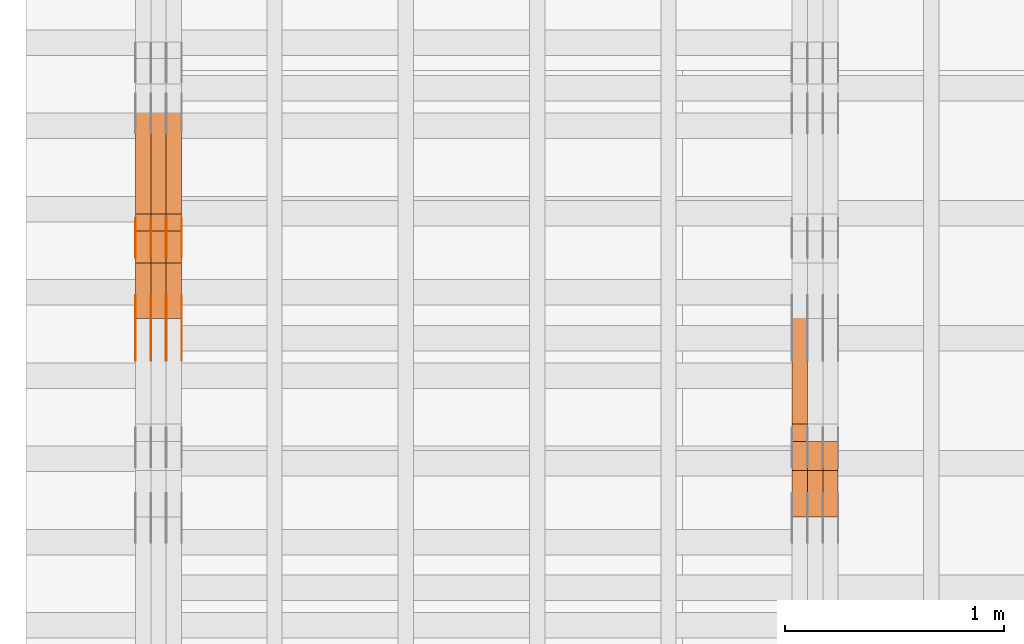
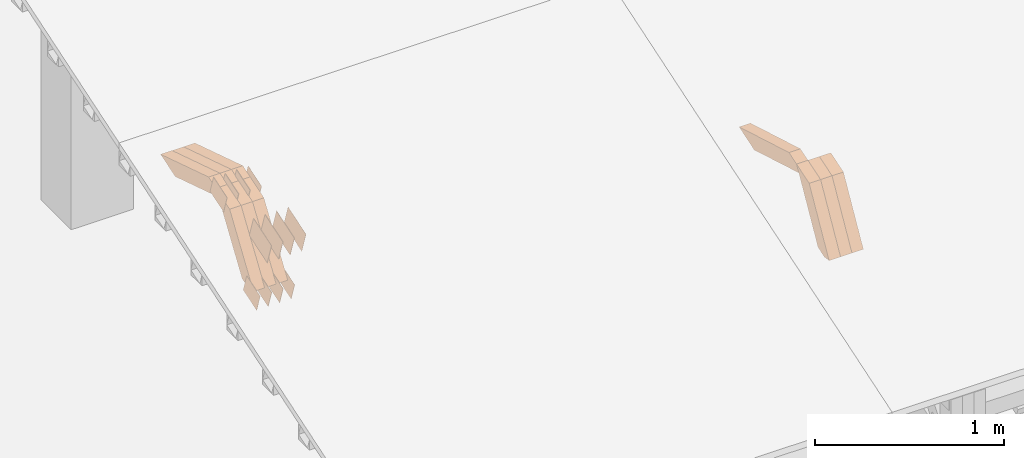
# One storey, part 36 of 385: 28 proxies.
"""IFC2X3 building model written with IfcOpenShell, lengths in millimetres."""

import ifcopenshell
import ifcopenshell.guid

model = None  # the IFC model being written
_history = None  # IfcOwnerHistory: only IFC2X3 demands one
_inside = {}  # id of a spatial element -> (the spatial element, [elements in it])
_under = {}  # id of a project, library or spatial element -> (it, [spatial elements below it])
_declared = {}  # id of a project -> (the project, [libraries it declares])
_typed = {}  # id of a type object -> (the type object, [elements of that type])
_made_of = {}  # id of a material, layer set ... -> (it, [elements and type objects made of it])


def new_model(schema):
    """Start an empty IFC model of exactly this schema.

    Asked for "IFC4X3", IfcOpenShell would pick the latest addendum, in which some entities
    have other attributes; the version numbers below select the first issue.
    IFC2X3 requires an IfcOwnerHistory on every rooted entity: one is made here for all.
    """
    global model, _history
    if schema == "IFC4X3":
        model = ifcopenshell.file(schema_version=(4, 3, 0, 0))
    else:
        model = ifcopenshell.file(schema=schema)
    _inside.clear()
    _under.clear()
    _declared.clear()
    _typed.clear()
    _made_of.clear()
    _history = None
    if model.schema == "IFC2X3":
        org = make("IfcOrganization", Name="unknown")
        user = make(
            "IfcPersonAndOrganization",
            ThePerson=make("IfcPerson", FamilyName="unknown"),
            TheOrganization=org,
        )
        app = make(
            "IfcApplication",
            ApplicationDeveloper=org,
            Version="unknown",
            ApplicationFullName="unknown",
            ApplicationIdentifier="unknown",
        )
        _history = make(
            "IfcOwnerHistory",
            OwningUser=user,
            OwningApplication=app,
            ChangeAction="ADDED",
            CreationDate=0,
        )
    return model


def make(cls, **values):
    """One entity of the class cls with the attributes given. An attribute that is None is left unset."""
    return model.create_entity(
        cls, **{name: value for name, value in values.items() if value is not None}
    )


def entity(cls, *values):
    """Any entity or typed value of the class cls, its attributes in the order of the schema. None: left unset."""
    e = model.create_entity(cls)
    for i, value in enumerate(values):
        if value is not None:
            e[i] = value
    return e


def rooted(cls, **values):
    """An entity with a GlobalId (a new one), such as an element, a storey or a relation."""
    return make(cls, GlobalId=ifcopenshell.guid.new(), OwnerHistory=_history, **values)


def si_unit(unit_type, name, prefix=None):
    """IfcSIUnit, for example si_unit("LENGTHUNIT", "METRE", prefix="MILLI")."""
    return make("IfcSIUnit", UnitType=unit_type, Prefix=prefix, Name=name)


def converted_unit(unit_type, name, factor, base, dimensions=None, offset=None):
    """IfcConversionBasedUnit, such as the inch: factor (a typed value) times the base unit."""
    return make(
        "IfcConversionBasedUnit"
        if offset is None
        else "IfcConversionBasedUnitWithOffset",
        ConversionOffset=offset,
        Dimensions=None
        if dimensions is None
        else entity("IfcDimensionalExponents", *dimensions),
        UnitType=unit_type,
        Name=name,
        ConversionFactor=make(
            "IfcMeasureWithUnit", ValueComponent=factor, UnitComponent=base
        ),
    )


def derived_unit(unit_type, elements):
    """IfcDerivedUnit: a product of units, each with its exponent."""
    return make(
        "IfcDerivedUnit",
        Elements=[
            make("IfcDerivedUnitElement", Unit=unit, Exponent=power)
            for unit, power in elements
        ],
        UnitType=unit_type,
    )


def assignment(units):
    """IfcUnitAssignment: the units of a project."""
    return None if units is None else make("IfcUnitAssignment", Units=units)


def point(xyz):
    """IfcCartesianPoint."""
    return None if xyz is None else make("IfcCartesianPoint", Coordinates=xyz)


def direction(xyz):
    """IfcDirection."""
    return None if xyz is None else make("IfcDirection", DirectionRatios=xyz)


def frame(location, z_axis=None, x_axis=None):
    """IfcAxis2Placement3D, a coordinate frame: its origin and axes. An axis left out is left unset."""
    return make(
        "IfcAxis2Placement3D",
        Location=point(location),
        Axis=direction(z_axis),
        RefDirection=direction(x_axis),
    )


def origin():
    """The frame at (0, 0, 0) with its axes left unset."""
    return frame((0.0, 0.0, 0.0))


def place(relative_to, where):
    """IfcLocalPlacement: puts the frame where relative to a parent placement (None: the world)."""
    return make(
        "IfcLocalPlacement", PlacementRelTo=relative_to, RelativePlacement=where
    )


def context(
    kind, dimensions, precision=None, world=None, true_north=None, identifier=None
):
    """IfcGeometricRepresentationContext, for example the 3D "Model" context."""
    return make(
        "IfcGeometricRepresentationContext",
        ContextIdentifier=identifier,
        ContextType=kind,
        CoordinateSpaceDimension=dimensions,
        Precision=precision,
        WorldCoordinateSystem=world,
        TrueNorth=true_north,
    )


def subcontext(parent, identifier, kind, view, scale=None):
    """IfcGeometricRepresentationSubContext, for example "Body" below "Model"."""
    return make(
        "IfcGeometricRepresentationSubContext",
        ContextIdentifier=identifier,
        ContextType=kind,
        ParentContext=parent,
        TargetScale=scale,
        TargetView=view,
    )


def project(units=None, contexts=None):
    """IfcProject with its units and contexts."""
    return rooted(
        "IfcProject",
        Name="project",
        RepresentationContexts=contexts,
        UnitsInContext=assignment(units),
    )


def spatial(cls, under=None, at=None, **own):
    """A site, building, storey or space (cls), placed at a placement, below another one or the project."""
    s = rooted(cls, ObjectPlacement=at, **own)
    if under is not None:
        _under.setdefault(under.id(), (under, []))[1].append(s)
    return s


def polyline(points):
    """IfcPolyline through the points."""
    return make("IfcPolyline", Points=[point(p) for p in points])


def outline(outer, holes=None, kind="AREA"):
    """IfcArbitraryClosedProfileDef: a profile drawn as a closed curve; with holes, ...WithVoids."""
    if holes is None:
        return make("IfcArbitraryClosedProfileDef", ProfileType=kind, OuterCurve=outer)
    return make(
        "IfcArbitraryProfileDefWithVoids",
        ProfileType=kind,
        OuterCurve=outer,
        InnerCurves=holes,
    )


def extrude(swept, where, along, depth):
    """IfcExtrudedAreaSolid: the profile swept, set in the frame where, extruded along a direction by depth."""
    return make(
        "IfcExtrudedAreaSolid",
        SweptArea=swept,
        Position=where,
        ExtrudedDirection=direction(along),
        Depth=depth,
    )


def shape(context_of_items, identifier, shape_type, items):
    """IfcShapeRepresentation: the items that make up one representation, for example the "Body"."""
    return make(
        "IfcShapeRepresentation",
        ContextOfItems=context_of_items,
        RepresentationIdentifier=identifier,
        RepresentationType=shape_type,
        Items=items,
    )


def source(mapping_origin, context_of_items, identifier, shape_type, items):
    """IfcRepresentationMap: a shape defined once, which mapped items show again and again."""
    return make(
        "IfcRepresentationMap",
        MappingOrigin=mapping_origin,
        MappedRepresentation=shape(context_of_items, identifier, shape_type, items),
    )


def transform(
    local_origin,
    x_axis=None,
    y_axis=None,
    z_axis=None,
    scale=None,
    scale2=None,
    scale3=None,
    uniform=True,
):
    """IfcCartesianTransformationOperator3D, or its non-uniform kind. x_axis, y_axis, z_axis: its Axis1, 2, 3."""
    if uniform:
        return make(
            "IfcCartesianTransformationOperator3D",
            Axis1=direction(x_axis),
            Axis2=direction(y_axis),
            LocalOrigin=point(local_origin),
            Scale=scale,
            Axis3=direction(z_axis),
        )
    return make(
        "IfcCartesianTransformationOperator3DnonUniform",
        Axis1=direction(x_axis),
        Axis2=direction(y_axis),
        LocalOrigin=point(local_origin),
        Scale=scale,
        Axis3=direction(z_axis),
        Scale2=scale2,
        Scale3=scale3,
    )


def mapped(mapping_source, mapping_target):
    """IfcMappedItem: shows the shape of a source again, moved by a transform."""
    return make(
        "IfcMappedItem", MappingSource=mapping_source, MappingTarget=mapping_target
    )


def material(Name=None, Category=None):
    """IfcMaterial."""
    return make("IfcMaterial", Name=Name, Category=Category)


def made_of(thing, what):
    """Note that an element or type object is made of a material, layer set ...; save() writes the relation."""
    if what is not None:
        _made_of.setdefault(what.id(), (what, []))[1].append(thing)
    return thing


def type_object(cls, material=None, **own):
    """A type object (cls), such as IfcWallType, which elements share."""
    return made_of(rooted(cls, **own), material)


def type_shapes(of_type, sources):
    """Give a type object the sources (RepresentationMaps) that its elements show as mapped items."""
    of_type.RepresentationMaps = sources


def element(
    cls,
    number,
    at=None,
    inside=None,
    cuts=None,
    type_object=None,
    material=None,
    context=None,
    identifier="Body",
    shape_type=None,
    held_by="IfcProductDefinitionShape",
    body=None,
    shapes=None,
    **own,
):
    """One element of the class cls, such as IfcWall. Its Tag is "e" and its number.

    at: its placement. inside: the storey or other place that contains it. cuts: it is an
    opening in that element (IfcRelVoidsElement). A single representation is given by context,
    identifier, shape_type and body (its items); several are given by shapes. held_by: the class
    of the entity that holds the representations. save() writes the other relations.
    """
    e = rooted(cls, Tag="e%d" % number, ObjectPlacement=at, **own)
    if body is not None:
        shapes = [shape(context, identifier, shape_type, body)]
    if shapes is not None:
        e.Representation = make(held_by, Representations=shapes)
    if inside is not None:
        _inside.setdefault(inside.id(), (inside, []))[1].append(e)
    if cuts is not None:
        rooted(
            "IfcRelVoidsElement", RelatingBuildingElement=cuts, RelatedOpeningElement=e
        )
    if type_object is not None:
        _typed.setdefault(type_object.id(), (type_object, []))[1].append(e)
    return made_of(e, material)


def aggregate(whole, parts):
    """IfcRelAggregates: a whole, such as a stair, and the parts it consists of."""
    return rooted("IfcRelAggregates", RelatingObject=whole, RelatedObjects=parts)


def save(model, path):
    """Write the relations noted so far, then the file.

    IfcRelAggregates (storeys below a building ...), IfcRelContainedInSpatialStructure (elements
    in a storey), IfcRelDefinesByType, IfcRelAssociatesMaterial and IfcRelDeclares: one each for
    every whole, place, type object, material and project.
    """
    for whole, parts in _under.values():
        aggregate(whole, parts)
    for where, things in _inside.values():
        rooted(
            "IfcRelContainedInSpatialStructure",
            RelatedElements=things,
            RelatingStructure=where,
        )
    for kind, things in _typed.values():
        rooted("IfcRelDefinesByType", RelatedObjects=things, RelatingType=kind)
    for what, things in _made_of.values():
        rooted("IfcRelAssociatesMaterial", RelatedObjects=things, RelatingMaterial=what)
    for by, libraries in _declared.values():
        rooted("IfcRelDeclares", RelatingContext=by, RelatedDefinitions=libraries)
    model.write(path)


model = new_model("IFC2X3")

# Units and contexts
model_context = context("Model", 3, precision=0.01, world=origin(), true_north=direction((6.12303176911189e-17, 1.0)))
body_context = subcontext(model_context, "Body", "Model", "MODEL_VIEW")
ifc_project = project(units=[si_unit("LENGTHUNIT", "METRE", prefix="MILLI"), si_unit("AREAUNIT", "SQUARE_METRE"), si_unit("VOLUMEUNIT", "CUBIC_METRE"), converted_unit("PLANEANGLEUNIT", "DEGREE", entity("IfcRatioMeasure", 0.0174532925199433), si_unit("PLANEANGLEUNIT", "RADIAN"), dimensions=[0, 0, 0, 0, 0, 0, 0]), si_unit("MASSUNIT", "GRAM", prefix="KILO"), derived_unit("MASSDENSITYUNIT", [(si_unit("MASSUNIT", "GRAM", prefix="KILO"), 1), (si_unit("LENGTHUNIT", "METRE"), -3)]), si_unit("TIMEUNIT", "SECOND"), si_unit("FREQUENCYUNIT", "HERTZ"), si_unit("THERMODYNAMICTEMPERATUREUNIT", "DEGREE_CELSIUS"), derived_unit("THERMALTRANSMITTANCEUNIT", [(si_unit("MASSUNIT", "GRAM", prefix="KILO"), 1), (si_unit("THERMODYNAMICTEMPERATUREUNIT", "KELVIN"), -1), (si_unit("TIMEUNIT", "SECOND"), -3)]), derived_unit("VOLUMETRICFLOWRATEUNIT", [(si_unit("LENGTHUNIT", "METRE"), 3), (si_unit("TIMEUNIT", "SECOND"), -1)]), si_unit("ELECTRICCURRENTUNIT", "AMPERE"), si_unit("ELECTRICVOLTAGEUNIT", "VOLT"), si_unit("POWERUNIT", "WATT"), si_unit("FORCEUNIT", "NEWTON", prefix="KILO"), si_unit("ILLUMINANCEUNIT", "LUX"), si_unit("LUMINOUSFLUXUNIT", "LUMEN"), si_unit("LUMINOUSINTENSITYUNIT", "CANDELA"), derived_unit("USERDEFINED", [(si_unit("MASSUNIT", "GRAM", prefix="KILO"), -1), (si_unit("LENGTHUNIT", "METRE"), -2), (si_unit("TIMEUNIT", "SECOND"), 3), (si_unit("LUMINOUSFLUXUNIT", "LUMEN"), 1)]), derived_unit("LINEARVELOCITYUNIT", [(si_unit("LENGTHUNIT", "METRE"), 1), (si_unit("TIMEUNIT", "SECOND"), -1)]), si_unit("PRESSUREUNIT", "PASCAL"), derived_unit("USERDEFINED", [(si_unit("LENGTHUNIT", "METRE"), -2), (si_unit("MASSUNIT", "GRAM", prefix="KILO"), 1), (si_unit("TIMEUNIT", "SECOND"), -2)])], contexts=[model_context])

# Site, building, storey
site_placement = place(None, origin())
site = spatial("IfcSite", under=ifc_project, at=site_placement, CompositionType="ELEMENT")
building_placement = place(site_placement, origin())
building = spatial("IfcBuilding", under=site, at=building_placement, CompositionType="ELEMENT")
storey_placement = place(building_placement, origin())
storey = spatial("IfcBuildingStorey", under=building, at=storey_placement, Name="Default", CompositionType="ELEMENT", Elevation=0.0)

# Proxies
ifc_material_1 = material(Name="IfcSurfaceStyle #44388")
building_element_proxy_type_1 = type_object("IfcBuildingElementProxyType", Name="T1-W12 44386", PredefinedType="NOTDEFINED", material=ifc_material_1)
shared_shape_1 = source(origin(), body_context, "Body", "SweptSolid", [
    extrude(outline(polyline([(-249.405625983165, -47.5001691155616), (243.345753908996, -47.5001691155616), (232.115534842595, 2.39993474701938e-05), (162.527010966644, 47.5001571158879), (-388.58267373507, 47.5001571158879), (-249.405625983165, -47.5001691155616)])), frame((243.345867653852, 47.5001571158879, 0.0), z_axis=(0.0, 0.0, 1.0), x_axis=(-1.0, 0.0, 0.0)), (0.0, 0.0, 1.0), 70.0),
])
type_shapes(building_element_proxy_type_1, [shared_shape_1])
proxy_1_placement = place(building_placement, frame((3245.0, 4581.32698473631, 976.172276753357), z_axis=(-1.0, 0.0, 0.0), x_axis=(0.0, 0.959722067881787, -0.280951156645966)))
element("IfcBuildingElementProxy", 1, at=proxy_1_placement, inside=storey, type_object=building_element_proxy_type_1, material=ifc_material_1, Name="T1-W12", context=body_context, shape_type="MappedRepresentation", body=[
    mapped(shared_shape_1, transform((0.0, 0.0, 0.0), scale=1.0)),
])
ifc_material_2 = material(Name="IfcSurfaceStyle #44124")
building_element_proxy_type_2 = type_object("IfcBuildingElementProxyType", Name="T1-W27 44122", PredefinedType="NOTDEFINED", material=ifc_material_2)
shared_shape_2 = source(origin(), body_context, "Body", "SweptSolid", [
    extrude(outline(polyline([(-321.979763159708, -47.49993999164), (138.960018341432, -47.49993999164), (191.013775341887, -0.000473170132329126), (209.87827169492, 47.5001765767061), (-217.872302218531, 47.5001765767062), (-321.979763159708, -47.49993999164)])), frame((209.87827169492, 47.5001765767061, 0.0), z_axis=(0.0, 0.0, 1.0), x_axis=(-1.0, 0.0, 0.0)), (0.0, 0.0, 1.0), 70.0),
])
type_shapes(building_element_proxy_type_2, [shared_shape_2])
proxy_2_placement = place(building_placement, frame((3385.0, 4233.3125, 512.021728515625), z_axis=(-1.0, 0.0, 0.0), x_axis=(0.0, 0.494231057369727, 0.869330582650352)))
element("IfcBuildingElementProxy", 2, at=proxy_2_placement, inside=storey, type_object=building_element_proxy_type_2, material=ifc_material_2, Name="T1-W27", context=body_context, shape_type="MappedRepresentation", body=[
    mapped(shared_shape_2, transform((0.0, 0.0, 0.0), scale=1.0)),
])
ifc_material_3 = material(Name="IfcSurfaceStyle #44058")
building_element_proxy_type_3 = type_object("IfcBuildingElementProxyType", Name="T1-W27 44056", PredefinedType="NOTDEFINED", material=ifc_material_3)
shared_shape_3 = source(origin(), body_context, "Body", "SweptSolid", [
    extrude(outline(polyline([(-321.979763159708, -47.49993999164), (138.960018341432, -47.49993999164), (191.013775341887, -0.000473170132329126), (209.87827169492, 47.5001765767061), (-217.872302218531, 47.5001765767062), (-321.979763159708, -47.49993999164)])), frame((209.87827169492, 47.5001765767061, 0.0), z_axis=(0.0, 0.0, 1.0), x_axis=(-1.0, 0.0, 0.0)), (0.0, 0.0, 1.0), 70.0),
])
type_shapes(building_element_proxy_type_3, [shared_shape_3])
proxy_3_placement = place(building_placement, frame((3315.0, 4233.3125, 512.021728515625), z_axis=(-1.0, 0.0, 0.0), x_axis=(0.0, 0.494231057369727, 0.869330582650352)))
element("IfcBuildingElementProxy", 3, at=proxy_3_placement, inside=storey, type_object=building_element_proxy_type_3, material=ifc_material_3, Name="T1-W27", context=body_context, shape_type="MappedRepresentation", body=[
    mapped(shared_shape_3, transform((0.0, 0.0, 0.0), scale=1.0)),
])
ifc_material_4 = material(Name="IfcSurfaceStyle #43992")
building_element_proxy_type_4 = type_object("IfcBuildingElementProxyType", Name="T1-W27 43990", PredefinedType="NOTDEFINED", material=ifc_material_4)
shared_shape_4 = source(origin(), body_context, "Body", "SweptSolid", [
    extrude(outline(polyline([(-321.979763159708, -47.49993999164), (138.960018341432, -47.49993999164), (191.013775341887, -0.000473170132329126), (209.87827169492, 47.5001765767061), (-217.872302218531, 47.5001765767062), (-321.979763159708, -47.49993999164)])), frame((209.87827169492, 47.5001765767061, 0.0), z_axis=(0.0, 0.0, 1.0), x_axis=(-1.0, 0.0, 0.0)), (0.0, 0.0, 1.0), 70.0),
])
type_shapes(building_element_proxy_type_4, [shared_shape_4])
proxy_4_placement = place(building_placement, frame((3245.0, 4233.3125, 512.021728515625), z_axis=(-1.0, 0.0, 0.0), x_axis=(0.0, 0.494231057369727, 0.869330582650352)))
element("IfcBuildingElementProxy", 4, at=proxy_4_placement, inside=storey, type_object=building_element_proxy_type_4, material=ifc_material_4, Name="T1-W27", context=body_context, shape_type="MappedRepresentation", body=[
    mapped(shared_shape_4, transform((0.0, 0.0, 0.0), scale=1.0)),
])
ifc_material_5 = material(Name="IfcSurfaceStyle #29456")
building_element_proxy_type_5 = type_object("IfcBuildingElementProxyType", PredefinedType="NOTDEFINED", material=ifc_material_5)
shared_shape_5 = source(origin(), body_context, "Body", "SweptSolid", [
    extrude(outline(polyline([(-74.9998707133927, -60.0000596852269), (74.9998841352353, -60.0000596852269), (74.999861282944, 60.0000596852269), (-74.9998747047866, 60.0000596852269), (-74.9998707133927, -60.0000596852269)])), frame((74.9998841352353, 60.0000596852269, 0.0), z_axis=(0.0, 0.0, 1.0), x_axis=(-1.0, 0.0, 0.0)), (0.0, 0.0, 1.0), 1.3),
])
type_shapes(building_element_proxy_type_5, [shared_shape_5])
proxy_5_placement = place(building_placement, frame((386.299999999986, 5067.4882362875, 826.131473120182), z_axis=(-1.0, 0.0, 0.0), x_axis=(0.0, 0.951056516295124, 0.309016994375039)))
element("IfcBuildingElementProxy", 5, at=proxy_5_placement, inside=storey, type_object=building_element_proxy_type_5, material=ifc_material_5, context=body_context, shape_type="MappedRepresentation", body=[
    mapped(shared_shape_5, transform((0.0, 0.0, 0.0), scale=1.0)),
])
ifc_material_6 = material(Name="IfcSurfaceStyle #29399")
building_element_proxy_type_6 = type_object("IfcBuildingElementProxyType", PredefinedType="NOTDEFINED", material=ifc_material_6)
shared_shape_6 = source(origin(), body_context, "Body", "SweptSolid", [
    extrude(outline(polyline([(-74.9998707133927, -60.0000596852269), (74.9998841352353, -60.0000596852269), (74.999861282944, 60.0000596852269), (-74.9998747047866, 60.0000596852269), (-74.9998707133927, -60.0000596852269)])), frame((74.9998841352353, 60.0000596852269, 0.0), z_axis=(0.0, 0.0, 1.0), x_axis=(-1.0, 0.0, 0.0)), (0.0, 0.0, 1.0), 1.3),
])
type_shapes(building_element_proxy_type_6, [shared_shape_6])
proxy_6_placement = place(building_placement, frame((315.0, 5067.4882362875, 826.131473120182), z_axis=(-1.0, 0.0, 0.0), x_axis=(0.0, 0.951056516295124, 0.309016994375039)))
element("IfcBuildingElementProxy", 6, at=proxy_6_placement, inside=storey, type_object=building_element_proxy_type_6, material=ifc_material_6, context=body_context, shape_type="MappedRepresentation", body=[
    mapped(shared_shape_6, transform((0.0, 0.0, 0.0), scale=1.0)),
])
ifc_material_7 = material(Name="IfcSurfaceStyle #29342")
building_element_proxy_type_7 = type_object("IfcBuildingElementProxyType", PredefinedType="NOTDEFINED", material=ifc_material_7)
shared_shape_7 = source(origin(), body_context, "Body", "SweptSolid", [
    extrude(outline(polyline([(-74.9998707133927, -60.0000596852269), (74.9998841352353, -60.0000596852269), (74.999861282944, 60.0000596852269), (-74.9998747047866, 60.0000596852269), (-74.9998707133927, -60.0000596852269)])), frame((74.9998841352353, 60.0000596852269, 0.0), z_axis=(0.0, 0.0, 1.0), x_axis=(-1.0, 0.0, 0.0)), (0.0, 0.0, 1.0), 1.3),
])
type_shapes(building_element_proxy_type_7, [shared_shape_7])
proxy_7_placement = place(building_placement, frame((316.299999999986, 5067.4882362875, 826.131473120182), z_axis=(-1.0, 0.0, 0.0), x_axis=(0.0, 0.951056516295124, 0.309016994375039)))
element("IfcBuildingElementProxy", 7, at=proxy_7_placement, inside=storey, type_object=building_element_proxy_type_7, material=ifc_material_7, context=body_context, shape_type="MappedRepresentation", body=[
    mapped(shared_shape_7, transform((0.0, 0.0, 0.0), scale=1.0)),
])
ifc_material_8 = material(Name="IfcSurfaceStyle #29285")
building_element_proxy_type_8 = type_object("IfcBuildingElementProxyType", PredefinedType="NOTDEFINED", material=ifc_material_8)
shared_shape_8 = source(origin(), body_context, "Body", "SweptSolid", [
    extrude(outline(polyline([(-74.9998707133927, -60.0000596852269), (74.9998841352353, -60.0000596852269), (74.999861282944, 60.0000596852269), (-74.9998747047866, 60.0000596852269), (-74.9998707133927, -60.0000596852269)])), frame((74.9998841352353, 60.0000596852269, 0.0), z_axis=(0.0, 0.0, 1.0), x_axis=(-1.0, 0.0, 0.0)), (0.0, 0.0, 1.0), 1.29999999999999),
])
type_shapes(building_element_proxy_type_8, [shared_shape_8])
proxy_8_placement = place(building_placement, frame((245.0, 5067.4882362875, 826.131473120182), z_axis=(-1.0, 0.0, 0.0), x_axis=(0.0, 0.951056516295124, 0.309016994375039)))
element("IfcBuildingElementProxy", 8, at=proxy_8_placement, inside=storey, type_object=building_element_proxy_type_8, material=ifc_material_8, context=body_context, shape_type="MappedRepresentation", body=[
    mapped(shared_shape_8, transform((0.0, 0.0, 0.0), scale=1.0)),
])
ifc_material_9 = material(Name="IfcSurfaceStyle #29228")
building_element_proxy_type_9 = type_object("IfcBuildingElementProxyType", PredefinedType="NOTDEFINED", material=ifc_material_9)
shared_shape_9 = source(origin(), body_context, "Body", "SweptSolid", [
    extrude(outline(polyline([(-74.9998707133927, -60.0000596852269), (74.9998841352353, -60.0000596852269), (74.999861282944, 60.0000596852269), (-74.9998747047866, 60.0000596852269), (-74.9998707133927, -60.0000596852269)])), frame((74.9998841352353, 60.0000596852269, 0.0), z_axis=(0.0, 0.0, 1.0), x_axis=(-1.0, 0.0, 0.0)), (0.0, 0.0, 1.0), 1.29999999999999),
])
type_shapes(building_element_proxy_type_9, [shared_shape_9])
proxy_9_placement = place(building_placement, frame((246.299999999986, 5067.4882362875, 826.131473120182), z_axis=(-1.0, 0.0, 0.0), x_axis=(0.0, 0.951056516295124, 0.309016994375039)))
element("IfcBuildingElementProxy", 9, at=proxy_9_placement, inside=storey, type_object=building_element_proxy_type_9, material=ifc_material_9, context=body_context, shape_type="MappedRepresentation", body=[
    mapped(shared_shape_9, transform((0.0, 0.0, 0.0), scale=1.0)),
])
ifc_material_10 = material(Name="IfcSurfaceStyle #29171")
building_element_proxy_type_10 = type_object("IfcBuildingElementProxyType", PredefinedType="NOTDEFINED", material=ifc_material_10)
shared_shape_10 = source(origin(), body_context, "Body", "SweptSolid", [
    extrude(outline(polyline([(-74.9998707133927, -60.0000596852269), (74.9998841352353, -60.0000596852269), (74.999861282944, 60.0000596852269), (-74.9998747047866, 60.0000596852269), (-74.9998707133927, -60.0000596852269)])), frame((74.9998841352353, 60.0000596852269, 0.0), z_axis=(0.0, 0.0, 1.0), x_axis=(-1.0, 0.0, 0.0)), (0.0, 0.0, 1.0), 1.29999999999999),
])
type_shapes(building_element_proxy_type_10, [shared_shape_10])
proxy_10_placement = place(building_placement, frame((175.0, 5067.4882362875, 826.131473120182), z_axis=(-1.0, 0.0, 0.0), x_axis=(0.0, 0.951056516295124, 0.309016994375039)))
element("IfcBuildingElementProxy", 10, at=proxy_10_placement, inside=storey, type_object=building_element_proxy_type_10, material=ifc_material_10, context=body_context, shape_type="MappedRepresentation", body=[
    mapped(shared_shape_10, transform((0.0, 0.0, 0.0), scale=1.0)),
])
ifc_material_11 = material(Name="IfcSurfaceStyle #23642")
building_element_proxy_type_11 = type_object("IfcBuildingElementProxyType", PredefinedType="NOTDEFINED", material=ifc_material_11)
shared_shape_11 = source(origin(), body_context, "Body", "SweptSolid", [
    extrude(outline(polyline([(-74.9998565677224, -60.0000596852342), (74.9998794200083, -60.0000596852342), (74.9998565677242, 60.0000596852342), (-74.9998794200101, 60.0000596852342), (-74.9998565677224, -60.0000596852342)])), frame((74.9998794200083, 60.0000596852342, 0.0), z_axis=(0.0, 0.0, 1.0), x_axis=(-1.0, 0.0, 0.0)), (0.0, 0.0, 1.0), 1.3),
])
type_shapes(building_element_proxy_type_11, [shared_shape_11])
proxy_11_placement = place(building_placement, frame((386.299999999986, 5418.6991737875, 1250.81341892098), z_axis=(-1.0, 0.0, 0.0), x_axis=(0.0, 0.951056516295154, 0.309016994374948)))
element("IfcBuildingElementProxy", 11, at=proxy_11_placement, inside=storey, type_object=building_element_proxy_type_11, material=ifc_material_11, context=body_context, shape_type="MappedRepresentation", body=[
    mapped(shared_shape_11, transform((0.0, 0.0, 0.0), scale=1.0)),
])
ifc_material_12 = material(Name="IfcSurfaceStyle #23585")
building_element_proxy_type_12 = type_object("IfcBuildingElementProxyType", PredefinedType="NOTDEFINED", material=ifc_material_12)
shared_shape_12 = source(origin(), body_context, "Body", "SweptSolid", [
    extrude(outline(polyline([(-74.9998565677224, -60.0000596852342), (74.9998794200083, -60.0000596852342), (74.9998565677242, 60.0000596852342), (-74.9998794200101, 60.0000596852342), (-74.9998565677224, -60.0000596852342)])), frame((74.9998794200083, 60.0000596852342, 0.0), z_axis=(0.0, 0.0, 1.0), x_axis=(-1.0, 0.0, 0.0)), (0.0, 0.0, 1.0), 1.3),
])
type_shapes(building_element_proxy_type_12, [shared_shape_12])
proxy_12_placement = place(building_placement, frame((315.0, 5418.6991737875, 1250.81341892098), z_axis=(-1.0, 0.0, 0.0), x_axis=(0.0, 0.951056516295154, 0.309016994374948)))
element("IfcBuildingElementProxy", 12, at=proxy_12_placement, inside=storey, type_object=building_element_proxy_type_12, material=ifc_material_12, context=body_context, shape_type="MappedRepresentation", body=[
    mapped(shared_shape_12, transform((0.0, 0.0, 0.0), scale=1.0)),
])
ifc_material_13 = material(Name="IfcSurfaceStyle #23528")
building_element_proxy_type_13 = type_object("IfcBuildingElementProxyType", PredefinedType="NOTDEFINED", material=ifc_material_13)
shared_shape_13 = source(origin(), body_context, "Body", "SweptSolid", [
    extrude(outline(polyline([(-74.9998565677224, -60.0000596852342), (74.9998794200083, -60.0000596852342), (74.9998565677242, 60.0000596852342), (-74.9998794200101, 60.0000596852342), (-74.9998565677224, -60.0000596852342)])), frame((74.9998794200083, 60.0000596852342, 0.0), z_axis=(0.0, 0.0, 1.0), x_axis=(-1.0, 0.0, 0.0)), (0.0, 0.0, 1.0), 1.3),
])
type_shapes(building_element_proxy_type_13, [shared_shape_13])
proxy_13_placement = place(building_placement, frame((316.299999999986, 5418.6991737875, 1250.81341892098), z_axis=(-1.0, 0.0, 0.0), x_axis=(0.0, 0.951056516295154, 0.309016994374948)))
element("IfcBuildingElementProxy", 13, at=proxy_13_placement, inside=storey, type_object=building_element_proxy_type_13, material=ifc_material_13, context=body_context, shape_type="MappedRepresentation", body=[
    mapped(shared_shape_13, transform((0.0, 0.0, 0.0), scale=1.0)),
])
ifc_material_14 = material(Name="IfcSurfaceStyle #23471")
building_element_proxy_type_14 = type_object("IfcBuildingElementProxyType", PredefinedType="NOTDEFINED", material=ifc_material_14)
shared_shape_14 = source(origin(), body_context, "Body", "SweptSolid", [
    extrude(outline(polyline([(-74.9998565677224, -60.0000596852342), (74.9998794200083, -60.0000596852342), (74.9998565677242, 60.0000596852342), (-74.9998794200101, 60.0000596852342), (-74.9998565677224, -60.0000596852342)])), frame((74.9998794200083, 60.0000596852342, 0.0), z_axis=(0.0, 0.0, 1.0), x_axis=(-1.0, 0.0, 0.0)), (0.0, 0.0, 1.0), 1.29999999999999),
])
type_shapes(building_element_proxy_type_14, [shared_shape_14])
proxy_14_placement = place(building_placement, frame((245.0, 5418.6991737875, 1250.81341892098), z_axis=(-1.0, 0.0, 0.0), x_axis=(0.0, 0.951056516295154, 0.309016994374948)))
element("IfcBuildingElementProxy", 14, at=proxy_14_placement, inside=storey, type_object=building_element_proxy_type_14, material=ifc_material_14, context=body_context, shape_type="MappedRepresentation", body=[
    mapped(shared_shape_14, transform((0.0, 0.0, 0.0), scale=1.0)),
])
ifc_material_15 = material(Name="IfcSurfaceStyle #23414")
building_element_proxy_type_15 = type_object("IfcBuildingElementProxyType", PredefinedType="NOTDEFINED", material=ifc_material_15)
shared_shape_15 = source(origin(), body_context, "Body", "SweptSolid", [
    extrude(outline(polyline([(-74.9998565677224, -60.0000596852342), (74.9998794200083, -60.0000596852342), (74.9998565677242, 60.0000596852342), (-74.9998794200101, 60.0000596852342), (-74.9998565677224, -60.0000596852342)])), frame((74.9998794200083, 60.0000596852342, 0.0), z_axis=(0.0, 0.0, 1.0), x_axis=(-1.0, 0.0, 0.0)), (0.0, 0.0, 1.0), 1.29999999999999),
])
type_shapes(building_element_proxy_type_15, [shared_shape_15])
proxy_15_placement = place(building_placement, frame((246.299999999986, 5418.6991737875, 1250.81341892098), z_axis=(-1.0, 0.0, 0.0), x_axis=(0.0, 0.951056516295154, 0.309016994374948)))
element("IfcBuildingElementProxy", 15, at=proxy_15_placement, inside=storey, type_object=building_element_proxy_type_15, material=ifc_material_15, context=body_context, shape_type="MappedRepresentation", body=[
    mapped(shared_shape_15, transform((0.0, 0.0, 0.0), scale=1.0)),
])
ifc_material_16 = material(Name="IfcSurfaceStyle #23357")
building_element_proxy_type_16 = type_object("IfcBuildingElementProxyType", PredefinedType="NOTDEFINED", material=ifc_material_16)
shared_shape_16 = source(origin(), body_context, "Body", "SweptSolid", [
    extrude(outline(polyline([(-74.9998565677224, -60.0000596852342), (74.9998794200083, -60.0000596852342), (74.9998565677242, 60.0000596852342), (-74.9998794200101, 60.0000596852342), (-74.9998565677224, -60.0000596852342)])), frame((74.9998794200083, 60.0000596852342, 0.0), z_axis=(0.0, 0.0, 1.0), x_axis=(-1.0, 0.0, 0.0)), (0.0, 0.0, 1.0), 1.29999999999999),
])
type_shapes(building_element_proxy_type_16, [shared_shape_16])
proxy_16_placement = place(building_placement, frame((175.0, 5418.6991737875, 1250.81341892098), z_axis=(-1.0, 0.0, 0.0), x_axis=(0.0, 0.951056516295154, 0.309016994374948)))
element("IfcBuildingElementProxy", 16, at=proxy_16_placement, inside=storey, type_object=building_element_proxy_type_16, material=ifc_material_16, context=body_context, shape_type="MappedRepresentation", body=[
    mapped(shared_shape_16, transform((0.0, 0.0, 0.0), scale=1.0)),
])
ifc_material_17 = material(Name="IfcSurfaceStyle #20222")
building_element_proxy_type_17 = type_object("IfcBuildingElementProxyType", PredefinedType="NOTDEFINED", material=ifc_material_17)
shared_shape_17 = source(origin(), body_context, "Body", "SweptSolid", [
    extrude(outline(polyline([(-99.9996257846169, -71.999973710258), (100.000009625089, -71.999973710258), (99.9996257846187, 71.999973710258), (-100.000009625091, 71.999973710258), (-99.9996257846169, -71.999973710258)])), frame((100.000083496635, 72.0000008245779, 0.0), z_axis=(0.0, 0.0, 1.0), x_axis=(-1.0, 0.0, 0.0)), (0.0, 0.0, 1.0), 1.3),
])
type_shapes(building_element_proxy_type_17, [shared_shape_17])
proxy_17_placement = place(building_placement, frame((386.299999999986, 4947.73195917316, 1225.53937157357), z_axis=(-1.0, 0.0, 0.0), x_axis=(0.0, 0.951056516295154, 0.309016994374948)))
element("IfcBuildingElementProxy", 17, at=proxy_17_placement, inside=storey, type_object=building_element_proxy_type_17, material=ifc_material_17, context=body_context, shape_type="MappedRepresentation", body=[
    mapped(shared_shape_17, transform((0.0, 0.0, 0.0), scale=1.0)),
])
ifc_material_18 = material(Name="IfcSurfaceStyle #20165")
building_element_proxy_type_18 = type_object("IfcBuildingElementProxyType", PredefinedType="NOTDEFINED", material=ifc_material_18)
shared_shape_18 = source(origin(), body_context, "Body", "SweptSolid", [
    extrude(outline(polyline([(-99.9996257846169, -71.999973710258), (100.000009625089, -71.999973710258), (99.9996257846187, 71.999973710258), (-100.000009625091, 71.999973710258), (-99.9996257846169, -71.999973710258)])), frame((100.000083496635, 72.0000008245779, 0.0), z_axis=(0.0, 0.0, 1.0), x_axis=(-1.0, 0.0, 0.0)), (0.0, 0.0, 1.0), 1.3),
])
type_shapes(building_element_proxy_type_18, [shared_shape_18])
proxy_18_placement = place(building_placement, frame((315.0, 4947.73195917316, 1225.53937157357), z_axis=(-1.0, 0.0, 0.0), x_axis=(0.0, 0.951056516295154, 0.309016994374948)))
element("IfcBuildingElementProxy", 18, at=proxy_18_placement, inside=storey, type_object=building_element_proxy_type_18, material=ifc_material_18, context=body_context, shape_type="MappedRepresentation", body=[
    mapped(shared_shape_18, transform((0.0, 0.0, 0.0), scale=1.0)),
])
ifc_material_19 = material(Name="IfcSurfaceStyle #20108")
building_element_proxy_type_19 = type_object("IfcBuildingElementProxyType", PredefinedType="NOTDEFINED", material=ifc_material_19)
shared_shape_19 = source(origin(), body_context, "Body", "SweptSolid", [
    extrude(outline(polyline([(-99.9996257846169, -71.999973710258), (100.000009625089, -71.999973710258), (99.9996257846187, 71.999973710258), (-100.000009625091, 71.999973710258), (-99.9996257846169, -71.999973710258)])), frame((100.000083496635, 72.0000008245779, 0.0), z_axis=(0.0, 0.0, 1.0), x_axis=(-1.0, 0.0, 0.0)), (0.0, 0.0, 1.0), 1.3),
])
type_shapes(building_element_proxy_type_19, [shared_shape_19])
proxy_19_placement = place(building_placement, frame((316.299999999986, 4947.73195917316, 1225.53937157357), z_axis=(-1.0, 0.0, 0.0), x_axis=(0.0, 0.951056516295154, 0.309016994374948)))
element("IfcBuildingElementProxy", 19, at=proxy_19_placement, inside=storey, type_object=building_element_proxy_type_19, material=ifc_material_19, context=body_context, shape_type="MappedRepresentation", body=[
    mapped(shared_shape_19, transform((0.0, 0.0, 0.0), scale=1.0)),
])
ifc_material_20 = material(Name="IfcSurfaceStyle #20051")
building_element_proxy_type_20 = type_object("IfcBuildingElementProxyType", PredefinedType="NOTDEFINED", material=ifc_material_20)
shared_shape_20 = source(origin(), body_context, "Body", "SweptSolid", [
    extrude(outline(polyline([(-99.9996257846169, -71.999973710258), (100.000009625089, -71.999973710258), (99.9996257846187, 71.999973710258), (-100.000009625091, 71.999973710258), (-99.9996257846169, -71.999973710258)])), frame((100.000083496635, 72.0000008245779, 0.0), z_axis=(0.0, 0.0, 1.0), x_axis=(-1.0, 0.0, 0.0)), (0.0, 0.0, 1.0), 1.29999999999998),
])
type_shapes(building_element_proxy_type_20, [shared_shape_20])
proxy_20_placement = place(building_placement, frame((245.0, 4947.73195917316, 1225.53937157357), z_axis=(-1.0, 0.0, 0.0), x_axis=(0.0, 0.951056516295154, 0.309016994374948)))
element("IfcBuildingElementProxy", 20, at=proxy_20_placement, inside=storey, type_object=building_element_proxy_type_20, material=ifc_material_20, context=body_context, shape_type="MappedRepresentation", body=[
    mapped(shared_shape_20, transform((0.0, 0.0, 0.0), scale=1.0)),
])
ifc_material_21 = material(Name="IfcSurfaceStyle #19994")
building_element_proxy_type_21 = type_object("IfcBuildingElementProxyType", PredefinedType="NOTDEFINED", material=ifc_material_21)
shared_shape_21 = source(origin(), body_context, "Body", "SweptSolid", [
    extrude(outline(polyline([(-99.9996257846169, -71.999973710258), (100.000009625089, -71.999973710258), (99.9996257846187, 71.999973710258), (-100.000009625091, 71.999973710258), (-99.9996257846169, -71.999973710258)])), frame((100.000083496635, 72.0000008245779, 0.0), z_axis=(0.0, 0.0, 1.0), x_axis=(-1.0, 0.0, 0.0)), (0.0, 0.0, 1.0), 1.29999999999998),
])
type_shapes(building_element_proxy_type_21, [shared_shape_21])
proxy_21_placement = place(building_placement, frame((246.299999999986, 4947.73195917316, 1225.53937157357), z_axis=(-1.0, 0.0, 0.0), x_axis=(0.0, 0.951056516295154, 0.309016994374948)))
element("IfcBuildingElementProxy", 21, at=proxy_21_placement, inside=storey, type_object=building_element_proxy_type_21, material=ifc_material_21, context=body_context, shape_type="MappedRepresentation", body=[
    mapped(shared_shape_21, transform((0.0, 0.0, 0.0), scale=1.0)),
])
ifc_material_22 = material(Name="IfcSurfaceStyle #19937")
building_element_proxy_type_22 = type_object("IfcBuildingElementProxyType", PredefinedType="NOTDEFINED", material=ifc_material_22)
shared_shape_22 = source(origin(), body_context, "Body", "SweptSolid", [
    extrude(outline(polyline([(-99.9996257846169, -71.999973710258), (100.000009625089, -71.999973710258), (99.9996257846187, 71.999973710258), (-100.000009625091, 71.999973710258), (-99.9996257846169, -71.999973710258)])), frame((100.000083496635, 72.0000008245779, 0.0), z_axis=(0.0, 0.0, 1.0), x_axis=(-1.0, 0.0, 0.0)), (0.0, 0.0, 1.0), 1.29999999999999),
])
type_shapes(building_element_proxy_type_22, [shared_shape_22])
proxy_22_placement = place(building_placement, frame((175.0, 4947.73195917316, 1225.53937157357), z_axis=(-1.0, 0.0, 0.0), x_axis=(0.0, 0.951056516295154, 0.309016994374948)))
element("IfcBuildingElementProxy", 22, at=proxy_22_placement, inside=storey, type_object=building_element_proxy_type_22, material=ifc_material_22, context=body_context, shape_type="MappedRepresentation", body=[
    mapped(shared_shape_22, transform((0.0, 0.0, 0.0), scale=1.0)),
])
ifc_material_23 = material(Name="IfcSurfaceStyle #10880")
building_element_proxy_type_23 = type_object("IfcBuildingElementProxyType", Name="T1-W15 10878", PredefinedType="NOTDEFINED", material=ifc_material_23)
shared_shape_23 = source(origin(), body_context, "Body", "SweptSolid", [
    extrude(outline(polyline([(-243.398341390642, -47.5000170814535), (237.775741169608, -47.5000170814535), (224.054017709933, 0.000127777485579883), (157.692261395711, 47.4999531927108), (-376.12367888461, 47.4999531927107), (-243.398341390642, -47.5000170814535)])), frame((237.77637044506, 47.5003404768297, 0.0), z_axis=(0.0, 0.0, 1.0), x_axis=(-1.0, 0.0, 0.0)), (0.0, 0.0, 1.0), 70.0),
])
type_shapes(building_element_proxy_type_23, [shared_shape_23])
proxy_23_placement = place(building_placement, frame((385.0, 5540.23242178142, 1288.84274826279), z_axis=(-1.0, 0.0, 0.0), x_axis=(0.0, 0.95322291386448, -0.302268219440466)))
element("IfcBuildingElementProxy", 23, at=proxy_23_placement, inside=storey, type_object=building_element_proxy_type_23, material=ifc_material_23, Name="T1-W15", context=body_context, shape_type="MappedRepresentation", body=[
    mapped(shared_shape_23, transform((0.0, 0.0, 0.0), scale=1.0)),
])
ifc_material_24 = material(Name="IfcSurfaceStyle #10814")
building_element_proxy_type_24 = type_object("IfcBuildingElementProxyType", Name="T1-W15 10812", PredefinedType="NOTDEFINED", material=ifc_material_24)
shared_shape_24 = source(origin(), body_context, "Body", "SweptSolid", [
    extrude(outline(polyline([(-243.398341390642, -47.5000170814535), (237.775741169608, -47.5000170814535), (224.054017709933, 0.000127777485579883), (157.692261395711, 47.4999531927108), (-376.12367888461, 47.4999531927107), (-243.398341390642, -47.5000170814535)])), frame((237.77637044506, 47.5003404768297, 0.0), z_axis=(0.0, 0.0, 1.0), x_axis=(-1.0, 0.0, 0.0)), (0.0, 0.0, 1.0), 70.0),
])
type_shapes(building_element_proxy_type_24, [shared_shape_24])
proxy_24_placement = place(building_placement, frame((315.0, 5540.23242178142, 1288.84274826279), z_axis=(-1.0, 0.0, 0.0), x_axis=(0.0, 0.95322291386448, -0.302268219440466)))
element("IfcBuildingElementProxy", 24, at=proxy_24_placement, inside=storey, type_object=building_element_proxy_type_24, material=ifc_material_24, Name="T1-W15", context=body_context, shape_type="MappedRepresentation", body=[
    mapped(shared_shape_24, transform((0.0, 0.0, 0.0), scale=1.0)),
])
ifc_material_25 = material(Name="IfcSurfaceStyle #10748")
building_element_proxy_type_25 = type_object("IfcBuildingElementProxyType", Name="T1-W15 10746", PredefinedType="NOTDEFINED", material=ifc_material_25)
shared_shape_25 = source(origin(), body_context, "Body", "SweptSolid", [
    extrude(outline(polyline([(-243.398341390642, -47.5000170814535), (237.775741169608, -47.5000170814535), (224.054017709933, 0.000127777485579883), (157.692261395711, 47.4999531927108), (-376.12367888461, 47.4999531927107), (-243.398341390642, -47.5000170814535)])), frame((237.77637044506, 47.5003404768297, 0.0), z_axis=(0.0, 0.0, 1.0), x_axis=(-1.0, 0.0, 0.0)), (0.0, 0.0, 1.0), 70.0),
])
type_shapes(building_element_proxy_type_25, [shared_shape_25])
proxy_25_placement = place(building_placement, frame((245.0, 5540.23242178142, 1288.84274826279), z_axis=(-1.0, 0.0, 0.0), x_axis=(0.0, 0.95322291386448, -0.302268219440466)))
element("IfcBuildingElementProxy", 25, at=proxy_25_placement, inside=storey, type_object=building_element_proxy_type_25, material=ifc_material_25, Name="T1-W15", context=body_context, shape_type="MappedRepresentation", body=[
    mapped(shared_shape_25, transform((0.0, 0.0, 0.0), scale=1.0)),
])
ifc_material_26 = material(Name="IfcSurfaceStyle #10484")
building_element_proxy_type_26 = type_object("IfcBuildingElementProxyType", Name="T1-W22 10482", PredefinedType="NOTDEFINED", material=ifc_material_26)
shared_shape_26 = source(origin(), body_context, "Body", "SweptSolid", [
    extrude(outline(polyline([(-351.940486061686, -47.5005995570677), (149.451602529695, -47.5005995570676), (209.614029773051, 0.000108554198836676), (224.491670779786, 47.5010029530092), (-231.616817020846, 47.5000876069273), (-351.940486061686, -47.5005995570677)])), frame((224.491766107217, 47.5005524294596, 0.0), z_axis=(0.0, 0.0, 1.0), x_axis=(-1.0, 2.00686044286885e-06, 0.0)), (0.0, 0.0, 1.0), 70.0),
])
type_shapes(building_element_proxy_type_26, [shared_shape_26])
proxy_26_placement = place(building_placement, frame((385.0, 5140.03125, 812.615600585936), z_axis=(-1.0, 0.0, 0.0), x_axis=(0.0, 0.554956576676696, 0.831879316970486)))
element("IfcBuildingElementProxy", 26, at=proxy_26_placement, inside=storey, type_object=building_element_proxy_type_26, material=ifc_material_26, Name="T1-W22", context=body_context, shape_type="MappedRepresentation", body=[
    mapped(shared_shape_26, transform((0.0, 0.0, 0.0), scale=1.0)),
])
ifc_material_27 = material(Name="IfcSurfaceStyle #10418")
building_element_proxy_type_27 = type_object("IfcBuildingElementProxyType", Name="T1-W22 10416", PredefinedType="NOTDEFINED", material=ifc_material_27)
shared_shape_27 = source(origin(), body_context, "Body", "SweptSolid", [
    extrude(outline(polyline([(-351.940486061686, -47.5005995570677), (149.451602529695, -47.5005995570676), (209.614029773051, 0.000108554198836676), (224.491670779786, 47.5010029530092), (-231.616817020846, 47.5000876069273), (-351.940486061686, -47.5005995570677)])), frame((224.491766107217, 47.5005524294596, 0.0), z_axis=(0.0, 0.0, 1.0), x_axis=(-1.0, 2.00686044286885e-06, 0.0)), (0.0, 0.0, 1.0), 70.0),
])
type_shapes(building_element_proxy_type_27, [shared_shape_27])
proxy_27_placement = place(building_placement, frame((315.0, 5140.03125, 812.615600585936), z_axis=(-1.0, 0.0, 0.0), x_axis=(0.0, 0.554956576676696, 0.831879316970486)))
element("IfcBuildingElementProxy", 27, at=proxy_27_placement, inside=storey, type_object=building_element_proxy_type_27, material=ifc_material_27, Name="T1-W22", context=body_context, shape_type="MappedRepresentation", body=[
    mapped(shared_shape_27, transform((0.0, 0.0, 0.0), scale=1.0)),
])
ifc_material_28 = material(Name="IfcSurfaceStyle #10352")
building_element_proxy_type_28 = type_object("IfcBuildingElementProxyType", Name="T1-W22 10350", PredefinedType="NOTDEFINED", material=ifc_material_28)
shared_shape_28 = source(origin(), body_context, "Body", "SweptSolid", [
    extrude(outline(polyline([(-351.940486061686, -47.5005995570677), (149.451602529695, -47.5005995570676), (209.614029773051, 0.000108554198836676), (224.491670779786, 47.5010029530092), (-231.616817020846, 47.5000876069273), (-351.940486061686, -47.5005995570677)])), frame((224.491766107217, 47.5005524294596, 0.0), z_axis=(0.0, 0.0, 1.0), x_axis=(-1.0, 2.00686044286885e-06, 0.0)), (0.0, 0.0, 1.0), 70.0),
])
type_shapes(building_element_proxy_type_28, [shared_shape_28])
proxy_28_placement = place(building_placement, frame((245.0, 5140.03125, 812.615600585936), z_axis=(-1.0, 0.0, 0.0), x_axis=(0.0, 0.554956576676696, 0.831879316970486)))
element("IfcBuildingElementProxy", 28, at=proxy_28_placement, inside=storey, type_object=building_element_proxy_type_28, material=ifc_material_28, Name="T1-W22", context=body_context, shape_type="MappedRepresentation", body=[
    mapped(shared_shape_28, transform((0.0, 0.0, 0.0), scale=1.0)),
])

save(model, "model.ifc")
